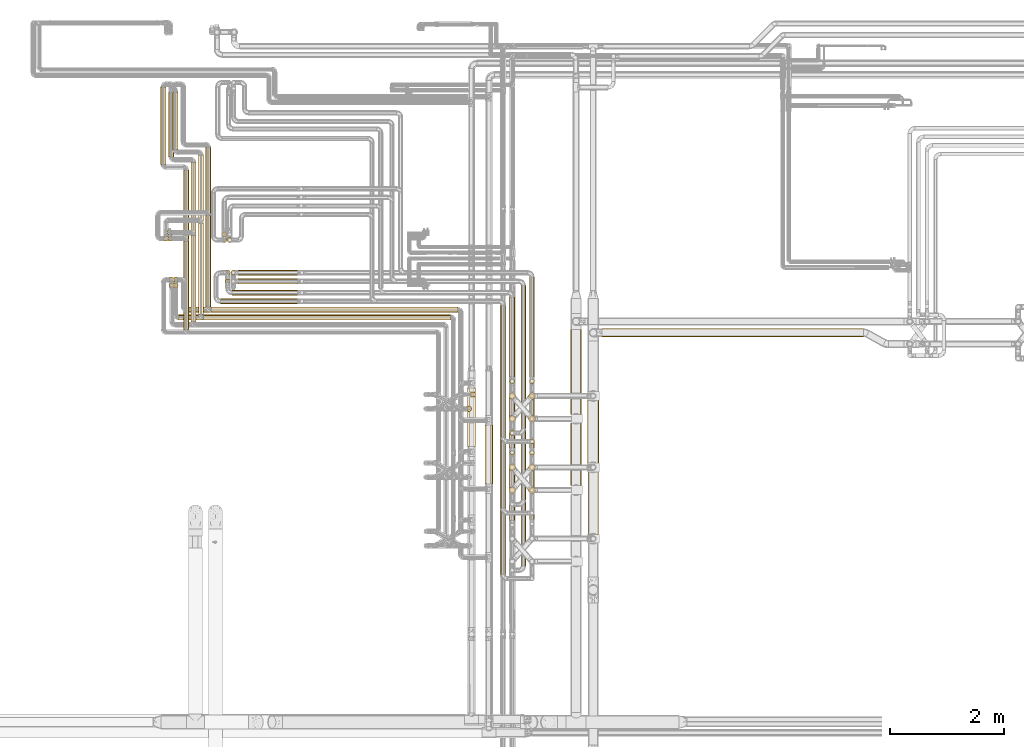
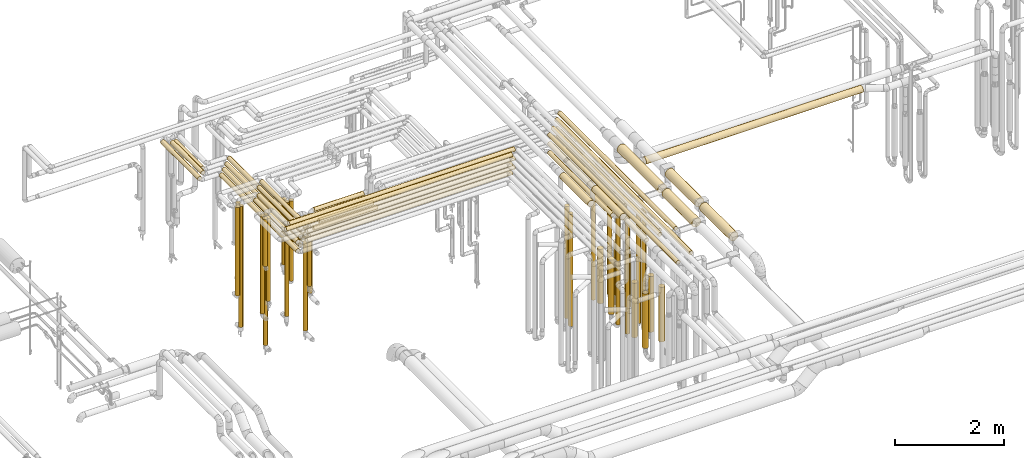
# One storey, part 5 of 827: 69 coverings.
"""IFC2X3 building model written with IfcOpenShell, lengths in millimetres."""

from ifc_helpers import new_model, entity, si_unit, converted_unit, derived_unit, direction, frame, origin, origin_2d_with_axis, place, context, subcontext, project, spatial, polyline, circle, outline, extrude, element, save


model = new_model("IFC2X3")

# Units and contexts
model_context = context("Model", 3, precision=0.01, world=origin(), true_north=direction((6.12303176911189e-17, 1.0)))
body_context = subcontext(model_context, "Body", "Model", "MODEL_VIEW")
ifc_project = project(units=[si_unit("LENGTHUNIT", "METRE", prefix="MILLI"), si_unit("AREAUNIT", "SQUARE_METRE"), si_unit("VOLUMEUNIT", "CUBIC_METRE"), converted_unit("PLANEANGLEUNIT", "DEGREE", entity("IfcRatioMeasure", 0.0174532925199433), si_unit("PLANEANGLEUNIT", "RADIAN"), dimensions=[0, 0, 0, 0, 0, 0, 0]), si_unit("MASSUNIT", "GRAM", prefix="KILO"), derived_unit("MASSDENSITYUNIT", [(si_unit("MASSUNIT", "GRAM", prefix="KILO"), 1), (si_unit("LENGTHUNIT", "METRE"), -3)]), derived_unit("MOMENTOFINERTIAUNIT", [(si_unit("LENGTHUNIT", "METRE"), 4)]), si_unit("TIMEUNIT", "SECOND"), si_unit("FREQUENCYUNIT", "HERTZ"), si_unit("THERMODYNAMICTEMPERATUREUNIT", "DEGREE_CELSIUS"), derived_unit("THERMALTRANSMITTANCEUNIT", [(si_unit("MASSUNIT", "GRAM", prefix="KILO"), 1), (si_unit("THERMODYNAMICTEMPERATUREUNIT", "KELVIN"), -1), (si_unit("TIMEUNIT", "SECOND"), -3)]), derived_unit("VOLUMETRICFLOWRATEUNIT", [(si_unit("LENGTHUNIT", "METRE"), 3), (si_unit("TIMEUNIT", "SECOND"), -1)]), derived_unit("MASSFLOWRATEUNIT", [(si_unit("MASSUNIT", "GRAM", prefix="KILO"), 1), (si_unit("TIMEUNIT", "SECOND"), -1)]), derived_unit("ROTATIONALFREQUENCYUNIT", [(si_unit("TIMEUNIT", "SECOND"), -1)]), si_unit("ELECTRICCURRENTUNIT", "AMPERE"), si_unit("ELECTRICVOLTAGEUNIT", "VOLT"), si_unit("POWERUNIT", "WATT"), si_unit("FORCEUNIT", "NEWTON", prefix="KILO"), si_unit("ILLUMINANCEUNIT", "LUX"), si_unit("LUMINOUSFLUXUNIT", "LUMEN"), si_unit("LUMINOUSINTENSITYUNIT", "CANDELA"), derived_unit("USERDEFINED", [(si_unit("MASSUNIT", "GRAM", prefix="KILO"), -1), (si_unit("LENGTHUNIT", "METRE"), -2), (si_unit("TIMEUNIT", "SECOND"), 3), (si_unit("LUMINOUSFLUXUNIT", "LUMEN"), 1)]), derived_unit("LINEARVELOCITYUNIT", [(si_unit("LENGTHUNIT", "METRE"), 1), (si_unit("TIMEUNIT", "SECOND"), -1)]), si_unit("PRESSUREUNIT", "PASCAL"), derived_unit("USERDEFINED", [(si_unit("LENGTHUNIT", "METRE"), -2), (si_unit("MASSUNIT", "GRAM", prefix="KILO"), 1), (si_unit("TIMEUNIT", "SECOND"), -2)]), derived_unit("LINEARFORCEUNIT", [(si_unit("MASSUNIT", "GRAM", prefix="KILO"), 1), (si_unit("LENGTHUNIT", "METRE"), 1), (si_unit("TIMEUNIT", "SECOND"), -2), (si_unit("LENGTHUNIT", "METRE"), -1)]), derived_unit("PLANARFORCEUNIT", [(si_unit("MASSUNIT", "GRAM", prefix="KILO"), 1), (si_unit("LENGTHUNIT", "METRE"), 1), (si_unit("TIMEUNIT", "SECOND"), -2), (si_unit("LENGTHUNIT", "METRE"), -2)])], contexts=[model_context])

# Site, building, storey
site_placement = place(None, origin())
site = spatial("IfcSite", under=ifc_project, at=site_placement, CompositionType="ELEMENT")
building_placement = place(site_placement, origin())
building = spatial("IfcBuilding", under=site, at=building_placement, CompositionType="ELEMENT")
storey_placement = place(building_placement, frame((0.0, 0.0, 28200.0)))
storey = spatial("IfcBuildingStorey", under=building, at=storey_placement, Name="08", CompositionType="ELEMENT", Elevation=28200.0)

# Coverings
covering_1_placement = place(storey_placement, frame((31258.78, 14538.0, 3152.25)))
element("IfcCovering", 1, at=covering_1_placement, inside=storey, Name=":ADSK_", ObjectType=":ADSK_", PredefinedType="INSULATION", context=body_context, shape_type="SweptSolid", body=[
    extrude(circle(Radius=46.15, at=origin_2d_with_axis()), frame((47.75, 0.0, 47.75), z_axis=(0.0, 1.0, 0.0), x_axis=(-1.0, 0.0, 0.0)), (0.0, 0.0, 1.0), 1605.20292594585),
])
covering_2_placement = place(storey_placement, frame((31128.78, 14408.0, 3152.25)))
element("IfcCovering", 2, at=covering_2_placement, inside=storey, Name=":ADSK_", ObjectType=":ADSK_", PredefinedType="INSULATION", context=body_context, shape_type="SweptSolid", body=[
    extrude(circle(Radius=46.15, at=origin_2d_with_axis()), frame((47.75, 0.0, 47.75), z_axis=(0.0, 1.0, 0.0), x_axis=(-1.0, 0.0, 0.0)), (0.0, 0.0, 1.0), 1605.20292594584),
])
covering_3_placement = place(storey_placement, frame((31354.52, 14442.26, 3152.25)))
element("IfcCovering", 3, at=covering_3_placement, inside=storey, Name=":ADSK_", ObjectType=":ADSK_", PredefinedType="INSULATION", context=body_context, shape_type="SweptSolid", body=[
    extrude(circle(Radius=46.15, at=origin_2d_with_axis()), frame((0.0, 47.75, 47.75), z_axis=(1.0, 0.0, 0.0), x_axis=(0.0, -1.0, 0.0)), (0.0, 0.0, 1.0), 4327.51165000005),
])
covering_4_placement = place(storey_placement, frame((31224.52, 14312.26, 3152.25)))
element("IfcCovering", 4, at=covering_4_placement, inside=storey, Name=":ADSK_", ObjectType=":ADSK_", PredefinedType="INSULATION", context=body_context, shape_type="SweptSolid", body=[
    extrude(circle(Radius=46.15, at=origin_2d_with_axis()), frame((0.0, 47.75, 47.75), z_axis=(1.0, 0.0, 0.0), x_axis=(0.0, -1.0, 0.0)), (0.0, 0.0, 1.0), 4327.56910000005),
])
covering_5_placement = place(storey_placement, frame((35847.22, 12092.08, 3479.16)))
element("IfcCovering", 5, at=covering_5_placement, inside=storey, Name=":ADSK_", ObjectType=":ADSK_", PredefinedType="INSULATION", context=body_context, shape_type="SweptSolid", body=[
    extrude(circle(Radius=69.25, at=origin_2d_with_axis()), frame((70.85, 0.0, 70.85), z_axis=(0.0, 1.0, -9.11558855625522e-08), x_axis=(1.0, 0.0, 0.0)), (0.0, 0.0, 1.0), 1028.00000000001),
])
covering_6_placement = place(storey_placement, frame((30779.54, 14312.26, 3352.25)))
element("IfcCovering", 6, at=covering_6_placement, inside=storey, Name=":ADSK_", ObjectType=":ADSK_", PredefinedType="INSULATION", context=body_context, shape_type="SweptSolid", body=[
    extrude(circle(Radius=46.15, at=origin_2d_with_axis()), frame((0.0, 47.75, 47.75), z_axis=(1.0, 0.0, 0.0), x_axis=(0.0, -1.0, 0.0)), (0.0, 0.0, 1.0), 4772.54583000002),
])
covering_7_placement = place(storey_placement, frame((30921.54, 14442.26, 3352.25)))
element("IfcCovering", 7, at=covering_7_placement, inside=storey, Name=":ADSK_", ObjectType=":ADSK_", PredefinedType="INSULATION", context=body_context, shape_type="SweptSolid", body=[
    extrude(circle(Radius=46.15, at=origin_2d_with_axis()), frame((0.0, 47.75, 47.75), z_axis=(1.0, 0.0, 0.0), x_axis=(0.0, -1.0, 0.0)), (0.0, 0.0, 1.0), 4760.48838000002),
])
covering_8_placement = place(storey_placement, frame((30683.55, 14968.46, 455.5)))
element("IfcCovering", 8, at=covering_8_placement, inside=storey, Name=":ADSK_", ObjectType=":ADSK_", PredefinedType="INSULATION", context=body_context, shape_type="SweptSolid", body=[
    extrude(circle(Radius=46.15, at=origin_2d_with_axis()), frame((47.75, 47.75, 0.0), z_axis=(0.0, 0.0, 1.0), x_axis=(0.0, 1.0, 0.0)), (0.0, 0.0, 1.0), 2896.50000000002),
])
covering_9_placement = place(storey_placement, frame((30683.8, 14868.46, 1500.5)))
element("IfcCovering", 9, at=covering_9_placement, inside=storey, Name=":ADSK_", ObjectType=":ADSK_", PredefinedType="INSULATION", context=body_context, shape_type="SweptSolid", body=[
    extrude(circle(Radius=46.15, at=origin_2d_with_axis()), frame((47.75, 47.75, 0.0), z_axis=(0.0, 0.0, 1.0), x_axis=(-1.0, 0.0, 0.0)), (0.0, 0.0, 1.0), 1851.50000000002),
])
covering_10_placement = place(storey_placement, frame((30515.78, 15693.46, 1178.45)))
element("IfcCovering", 10, at=covering_10_placement, inside=storey, Name=":ADSK_", ObjectType=":ADSK_", PredefinedType="INSULATION", context=body_context, shape_type="SweptSolid", body=[
    extrude(circle(Radius=46.15, at=origin_2d_with_axis()), frame((47.75, 47.75, 0.0), z_axis=(0.0, 0.0, 1.0), x_axis=(0.0, 1.0, 0.0)), (0.0, 0.0, 1.0), 1973.5517399999),
])
covering_11_placement = place(storey_placement, frame((30998.78, 14278.0, 3152.25)))
element("IfcCovering", 11, at=covering_11_placement, inside=storey, Name=":ADSK_", ObjectType=":ADSK_", PredefinedType="INSULATION", context=body_context, shape_type="SweptSolid", body=[
    extrude(circle(Radius=46.15, at=origin_2d_with_axis()), frame((47.75, 0.0, 47.75), z_axis=(0.0, 1.0, 0.0), x_axis=(-1.0, 0.0, 0.0)), (0.0, 0.0, 1.0), 1515.20292594584),
])
covering_12_placement = place(storey_placement, frame((30868.78, 14148.0, 3152.25)))
element("IfcCovering", 12, at=covering_12_placement, inside=storey, Name=":ADSK_", ObjectType=":ADSK_", PredefinedType="INSULATION", context=body_context, shape_type="SweptSolid", body=[
    extrude(circle(Radius=46.15, at=origin_2d_with_axis()), frame((47.75, 0.0, 47.75), z_axis=(0.0, 1.0, 0.0), x_axis=(-1.0, 0.0, 0.0)), (0.0, 0.0, 1.0), 1545.20292594584),
])
covering_13_placement = place(storey_placement, frame((36149.19, 11442.08, 3479.15)))
element("IfcCovering", 13, at=covering_13_placement, inside=storey, Name=":ADSK_", ObjectType=":ADSK_", PredefinedType="INSULATION", context=body_context, shape_type="SweptSolid", body=[
    extrude(circle(Radius=69.25, at=origin_2d_with_axis()), frame((70.85, 0.0, 70.85), z_axis=(0.0, 1.0, -9.11558897760429e-08), x_axis=(1.0, 0.0, 0.0)), (0.0, 0.0, 1.0), 1028.00000000001),
])
covering_14_placement = place(storey_placement, frame((30622.59, 14868.46, 2298.45)))
element("IfcCovering", 14, at=covering_14_placement, inside=storey, Name=":ADSK_", ObjectType=":ADSK_", PredefinedType="INSULATION", context=body_context, shape_type="SweptSolid", body=[
    extrude(circle(Radius=46.15, at=origin_2d_with_axis()), frame((47.75, 47.75, 0.0), z_axis=(0.0, 0.0, 1.0), x_axis=(-1.0, 0.0, 0.0)), (0.0, 0.0, 1.0), 1053.55173999999),
])
covering_15_placement = place(storey_placement, frame((30618.78, 14968.46, 1178.45)))
element("IfcCovering", 15, at=covering_15_placement, inside=storey, Name=":ADSK_", ObjectType=":ADSK_", PredefinedType="INSULATION", context=body_context, shape_type="SweptSolid", body=[
    extrude(circle(Radius=46.15, at=origin_2d_with_axis()), frame((47.75, 47.75, 0.0), z_axis=(0.0, 0.0, 1.0), x_axis=(0.0, 1.0, 0.0)), (0.0, 0.0, 1.0), 2173.55173999987),
])
covering_16_placement = place(storey_placement, frame((30583.78, 15793.46, 1500.5)))
element("IfcCovering", 16, at=covering_16_placement, inside=storey, Name=":ADSK_", ObjectType=":ADSK_", PredefinedType="INSULATION", context=body_context, shape_type="SweptSolid", body=[
    extrude(circle(Radius=46.15, at=origin_2d_with_axis()), frame((47.75, 47.75, 0.0), z_axis=(0.0, 0.0, 1.0), x_axis=(0.0, -1.0, 0.0)), (0.0, 0.0, 1.0), 1651.50000000004),
])
covering_17_placement = place(storey_placement, frame((30583.78, 15693.46, 455.5)))
element("IfcCovering", 17, at=covering_17_placement, inside=storey, Name=":ADSK_", ObjectType=":ADSK_", PredefinedType="INSULATION", context=body_context, shape_type="SweptSolid", body=[
    extrude(circle(Radius=46.15, at=origin_2d_with_axis()), frame((47.75, 47.75, 0.0), z_axis=(0.0, 0.0, 1.0), x_axis=(-1.0, 0.0, 0.0)), (0.0, 0.0, 1.0), 2696.50000000011),
])
covering_18_placement = place(storey_placement, frame((30677.33, 17299.2, 2952.25)))
element("IfcCovering", 18, at=covering_18_placement, inside=storey, Name=":ADSK_", ObjectType=":ADSK_", PredefinedType="INSULATION", context=body_context, shape_type="SweptSolid", body=[
    extrude(circle(Radius=46.15, at=origin_2d_with_axis()), frame((47.75, 0.0, 47.75), z_axis=(0.0, 1.0, 0.0), x_axis=(1.0, 0.0, 0.0)), (0.0, 0.0, 1.0), 993.999999999995),
])
covering_19_placement = place(storey_placement, frame((31128.78, 14408.0, 2952.25)))
element("IfcCovering", 19, at=covering_19_placement, inside=storey, Name=":ADSK_", ObjectType=":ADSK_", PredefinedType="INSULATION", context=body_context, shape_type="SweptSolid", body=[
    extrude(circle(Radius=46.15, at=origin_2d_with_axis()), frame((47.75, 0.0, 47.75), z_axis=(0.0, 1.0, 0.0), x_axis=(1.0, 0.0, 0.0)), (0.0, 0.0, 1.0), 2795.20292594584),
])
covering_20_placement = place(storey_placement, frame((31224.52, 14312.26, 2952.25)))
element("IfcCovering", 20, at=covering_20_placement, inside=storey, Name=":ADSK_", ObjectType=":ADSK_", PredefinedType="INSULATION", context=body_context, shape_type="SweptSolid", body=[
    extrude(circle(Radius=46.15, at=origin_2d_with_axis()), frame((0.0, 47.75, 47.75), z_axis=(1.0, 0.0, 0.0), x_axis=(0.0, 1.0, 0.0)), (0.0, 0.0, 1.0), 4327.56910000003),
])
covering_21_placement = place(storey_placement, frame((30609.3, 17169.2, 2952.25)))
element("IfcCovering", 21, at=covering_21_placement, inside=storey, Name=":ADSK_", ObjectType=":ADSK_", PredefinedType="INSULATION", context=body_context, shape_type="SweptSolid", body=[
    extrude(circle(Radius=46.15, at=origin_2d_with_axis()), frame((47.75, 0.0, 47.75), z_axis=(0.0, 1.0, 0.0), x_axis=(-1.0, 0.0, 0.0)), (0.0, 0.0, 1.0), 1124.0),
])
covering_22_placement = place(storey_placement, frame((30998.78, 14278.0, 2952.25)))
element("IfcCovering", 22, at=covering_22_placement, inside=storey, Name=":ADSK_", ObjectType=":ADSK_", PredefinedType="INSULATION", context=body_context, shape_type="SweptSolid", body=[
    extrude(circle(Radius=46.15, at=origin_2d_with_axis()), frame((47.75, 0.0, 47.75), z_axis=(0.0, 1.0, 0.0), x_axis=(1.0, 0.0, 0.0)), (0.0, 0.0, 1.0), 2795.20292594584),
])
covering_23_placement = place(storey_placement, frame((35826.04, 12708.42, 448.0)))
element("IfcCovering", 23, at=covering_23_placement, inside=storey, Name=":ADSK_", ObjectType=":ADSK_", PredefinedType="INSULATION", context=body_context, shape_type="SweptSolid", body=[
    extrude(circle(Radius=46.15, at=origin_2d_with_axis()), frame((47.75, 47.75, 0.0), z_axis=(0.0, 0.0, 1.0), x_axis=(-1.0, 0.0, 0.0)), (0.0, 0.0, 1.0), 2504.0),
])
covering_24_placement = place(storey_placement, frame((31354.52, 14442.26, 2952.25)))
element("IfcCovering", 24, at=covering_24_placement, inside=storey, Name=":ADSK_", ObjectType=":ADSK_", PredefinedType="INSULATION", context=body_context, shape_type="SweptSolid", body=[
    extrude(circle(Radius=46.15, at=origin_2d_with_axis()), frame((0.0, 47.75, 47.75), z_axis=(1.0, 0.0, 0.0), x_axis=(0.0, 1.0, 0.0)), (0.0, 0.0, 1.0), 4327.51165000003),
])
covering_25_placement = place(storey_placement, frame((31258.78, 14538.0, 2952.25)))
element("IfcCovering", 25, at=covering_25_placement, inside=storey, Name=":ADSK_", ObjectType=":ADSK_", PredefinedType="INSULATION", context=body_context, shape_type="SweptSolid", body=[
    extrude(circle(Radius=46.15, at=origin_2d_with_axis()), frame((47.75, 0.0, 47.75), z_axis=(0.0, 1.0, 0.0), x_axis=(-1.0, 0.0, 0.0)), (0.0, 0.0, 1.0), 2795.20292594584),
])
covering_26_placement = place(storey_placement, frame((35895.3, 12958.46, 448.0)))
element("IfcCovering", 26, at=covering_26_placement, inside=storey, Name=":ADSK_", ObjectType=":ADSK_", PredefinedType="INSULATION", context=body_context, shape_type="SweptSolid", body=[
    extrude(circle(Radius=46.15, at=origin_2d_with_axis()), frame((47.75, 47.75, 0.0), z_axis=(0.0, 0.0, 1.0), x_axis=(-1.0, 0.0, 0.0)), (0.0, 0.0, 1.0), 2504.0),
])
covering_27_placement = place(storey_placement, frame((30467.3, 17039.2, 2952.25)))
element("IfcCovering", 27, at=covering_27_placement, inside=storey, Name=":ADSK_", ObjectType=":ADSK_", PredefinedType="INSULATION", context=body_context, shape_type="SweptSolid", body=[
    extrude(circle(Radius=46.15, at=origin_2d_with_axis()), frame((47.75, 0.0, 47.75), z_axis=(0.0, 1.0, 0.0), x_axis=(-1.0, 0.0, 0.0)), (0.0, 0.0, 1.0), 1353.99999995382),
])
covering_28_placement = place(storey_placement, frame((30868.78, 14148.0, 2952.25)))
element("IfcCovering", 28, at=covering_28_placement, inside=storey, Name=":ADSK_", ObjectType=":ADSK_", PredefinedType="INSULATION", context=body_context, shape_type="SweptSolid", body=[
    extrude(circle(Radius=46.15, at=origin_2d_with_axis()), frame((47.75, 0.0, 47.75), z_axis=(0.0, 1.0, 0.0), x_axis=(1.0, 0.0, 0.0)), (0.0, 0.0, 1.0), 2795.20292594584),
])
covering_29_placement = place(storey_placement, frame((36423.44, 12257.17, 2953.4)))
element("IfcCovering", 29, at=covering_29_placement, inside=storey, Name=":ADSK_", ObjectType=":ADSK_", PredefinedType="INSULATION", context=body_context, shape_type="SweptSolid", body=[
    extrude(circle(Radius=45.0, at=origin_2d_with_axis()), frame((46.6, 0.0, 46.6), z_axis=(0.0, 1.0, 0.0), x_axis=(-1.0, 0.0, 0.0)), (0.0, 0.0, 1.0), 2306.8258040542),
])
covering_30_placement = place(storey_placement, frame((36928.44, 12134.58, 476.0)))
element("IfcCovering", 30, at=covering_30_placement, inside=storey, Name=":ADSK_", ObjectType=":ADSK_", PredefinedType="INSULATION", context=body_context, shape_type="SweptSolid", body=[
    extrude(outline(polyline([(-5.87, -44.62), (5.87, -44.62), (17.22, -41.57), (27.39, -35.7), (35.7, -27.39), (41.57, -17.22), (44.62, -5.87), (44.62, 5.87), (41.57, 17.22), (35.7, 27.39), (27.39, 35.7), (17.22, 41.57), (5.87, 44.62), (-5.87, 44.62), (-17.22, 41.57), (-27.39, 35.7), (-35.7, 27.39), (-41.57, 17.22), (-44.62, 5.87), (-44.62, -5.87), (-41.57, -17.22), (-35.7, -27.39), (-27.39, -35.7), (-17.22, -41.57), (-5.87, -44.62)])), frame((46.6, 46.6, 0.0), z_axis=(-3.67749217620578e-09, 0.0, 1.0), x_axis=(-0.130526192220067, 0.991444861373808, 0.0)), (0.0, 0.0, 1.0), 2447.99999099997),
])
covering_31_placement = place(storey_placement, frame((36583.05, 13316.2, 2953.4)))
element("IfcCovering", 31, at=covering_31_placement, inside=storey, Name=":ADSK_", ObjectType=":ADSK_", PredefinedType="INSULATION", context=body_context, shape_type="SweptSolid", body=[
    extrude(circle(Radius=45.0, at=origin_2d_with_axis()), frame((46.6, 0.0, 46.6), z_axis=(0.0, 1.0, 0.0), x_axis=(1.0, 0.0, 0.0)), (0.0, 0.0, 1.0), 1397.79727405418),
])
covering_32_placement = place(storey_placement, frame((36583.05, 13193.61, 476.0)))
element("IfcCovering", 32, at=covering_32_placement, inside=storey, Name=":ADSK_", ObjectType=":ADSK_", PredefinedType="INSULATION", context=body_context, shape_type="SweptSolid", body=[
    extrude(circle(Radius=45.0, at=origin_2d_with_axis()), frame((46.6, 46.6, 0.0)), (0.0, 0.0, 1.0), 2447.99999999999),
])
covering_33_placement = place(storey_placement, frame((36423.44, 11007.17, 3153.4)))
element("IfcCovering", 33, at=covering_33_placement, inside=storey, Name=":ADSK_", ObjectType=":ADSK_", PredefinedType="INSULATION", context=body_context, shape_type="SweptSolid", body=[
    extrude(circle(Radius=45.0, at=origin_2d_with_axis()), frame((46.6, 0.0, 46.6), z_axis=(0.0, 1.0, 0.0), x_axis=(-1.0, 0.0, 0.0)), (0.0, 0.0, 1.0), 3556.82579505427),
])
covering_34_placement = place(storey_placement, frame((36583.05, 12066.2, 3153.4)))
element("IfcCovering", 34, at=covering_34_placement, inside=storey, Name=":ADSK_", ObjectType=":ADSK_", PredefinedType="INSULATION", context=body_context, shape_type="SweptSolid", body=[
    extrude(circle(Radius=45.0, at=origin_2d_with_axis()), frame((46.6, 0.0, 46.6), z_axis=(0.0, 1.0, 0.0), x_axis=(1.0, 0.0, 0.0)), (0.0, 0.0, 1.0), 2647.79726505419),
])
covering_35_placement = place(storey_placement, frame((36423.44, 9857.02, 3353.4)))
element("IfcCovering", 35, at=covering_35_placement, inside=storey, Name=":ADSK_", ObjectType=":ADSK_", PredefinedType="INSULATION", context=body_context, shape_type="SweptSolid", body=[
    extrude(circle(Radius=45.0, at=origin_2d_with_axis()), frame((46.6, 0.0, 46.6), z_axis=(0.0, 1.0, 0.0), x_axis=(-1.0, 0.0, 0.0)), (0.0, 0.0, 1.0), 4706.97582205429),
])
covering_36_placement = place(storey_placement, frame((36583.05, 10795.72, 3353.4)))
element("IfcCovering", 36, at=covering_36_placement, inside=storey, Name=":ADSK_", ObjectType=":ADSK_", PredefinedType="INSULATION", context=body_context, shape_type="SweptSolid", body=[
    extrude(circle(Radius=45.0, at=origin_2d_with_axis()), frame((46.6, 0.0, 46.6), z_axis=(0.0, 1.0, 0.0), x_axis=(-1.0, 0.0, 0.0)), (0.0, 0.0, 1.0), 3918.27777979508),
])
covering_37_placement = place(storey_placement, frame((36583.05, 11943.61, 476.0)))
element("IfcCovering", 37, at=covering_37_placement, inside=storey, Name=":ADSK_", ObjectType=":ADSK_", PredefinedType="INSULATION", context=body_context, shape_type="SweptSolid", body=[
    extrude(circle(Radius=45.0, at=origin_2d_with_axis()), frame((46.6, 46.6, 0.0)), (0.0, 0.0, 1.0), 2648.0),
])
covering_38_placement = place(storey_placement, frame((36568.8, 11669.36, 565.0)))
element("IfcCovering", 38, at=covering_38_placement, inside=storey, Name=":ADSK_", ObjectType=":ADSK_", PredefinedType="INSULATION", context=body_context, shape_type="SweptSolid", body=[
    extrude(circle(Radius=59.25, at=origin_2d_with_axis()), frame((60.85, 60.85, 0.0), z_axis=(0.0, 0.0, 1.0), x_axis=(-1.0, 0.0, 0.0)), (0.0, 0.0, 1.0), 1215.99999999999),
])
covering_39_placement = place(storey_placement, frame((31517.75, 14593.41, 2953.4)))
element("IfcCovering", 39, at=covering_39_placement, inside=storey, Name=":ADSK_", ObjectType=":ADSK_", PredefinedType="INSULATION", context=body_context, shape_type="SweptSolid", body=[
    extrude(circle(Radius=45.0, at=origin_2d_with_axis()), frame((0.0, 46.6, 46.6), z_axis=(1.0, 0.0, 0.0), x_axis=(0.0, -1.0, 0.0)), (0.0, 0.0, 1.0), 1351.28244),
])
covering_40_placement = place(storey_placement, frame((31722.75, 14743.41, 2953.4)))
element("IfcCovering", 40, at=covering_40_placement, inside=storey, Name=":ADSK_", ObjectType=":ADSK_", PredefinedType="INSULATION", context=body_context, shape_type="SweptSolid", body=[
    extrude(circle(Radius=45.0, at=origin_2d_with_axis()), frame((0.0, 46.6, 46.6), z_axis=(1.0, 0.0, 0.0), x_axis=(0.0, 1.0, 0.0)), (0.0, 0.0, 1.0), 1146.28244),
])
covering_41_placement = place(storey_placement, frame((31600.16, 15092.41, 379.5)))
element("IfcCovering", 41, at=covering_41_placement, inside=storey, Name=":ADSK_", ObjectType=":ADSK_", PredefinedType="INSULATION", context=body_context, shape_type="SweptSolid", body=[
    extrude(circle(Radius=45.0, at=origin_2d_with_axis()), frame((46.6, 46.6, 0.0), z_axis=(0.0, 0.0, 1.0), x_axis=(0.0, -1.0, 0.0)), (0.0, 0.0, 1.0), 2544.50000000001),
])
covering_42_placement = place(storey_placement, frame((31600.16, 14942.41, 1469.5)))
element("IfcCovering", 42, at=covering_42_placement, inside=storey, Name=":ADSK_", ObjectType=":ADSK_", PredefinedType="INSULATION", context=body_context, shape_type="SweptSolid", body=[
    extrude(circle(Radius=45.0, at=origin_2d_with_axis()), frame((46.6, 46.6, 0.0), z_axis=(0.0, 0.0, 1.0), x_axis=(-1.0, 0.0, 0.0)), (0.0, 0.0, 1.0), 1454.50000000002),
])
covering_43_placement = place(storey_placement, frame((31633.66, 15664.61, 1136.0)))
element("IfcCovering", 43, at=covering_43_placement, inside=storey, Name=":ADSK_", ObjectType=":ADSK_", PredefinedType="INSULATION", context=body_context, shape_type="SweptSolid", body=[
    extrude(circle(Radius=45.0, at=origin_2d_with_axis()), frame((46.6, 46.6, 0.0), z_axis=(0.0, 0.0, 1.0), x_axis=(0.0, 1.0, 0.0)), (0.0, 0.0, 1.0), 1788.00000000001),
])
covering_44_placement = place(storey_placement, frame((36914.19, 11269.36, 589.0)))
element("IfcCovering", 44, at=covering_44_placement, inside=storey, Name=":ADSK_", ObjectType=":ADSK_", PredefinedType="INSULATION", context=body_context, shape_type="SweptSolid", body=[
    extrude(circle(Radius=59.25, at=origin_2d_with_axis()), frame((60.85, 60.85, 0.0), z_axis=(0.0, 0.0, 1.0), x_axis=(0.0, -1.0, 0.0)), (0.0, 0.0, 1.0), 1222.00000649532),
])
covering_45_placement = place(storey_placement, frame((36914.19, 12520.33, 589.0)))
element("IfcCovering", 45, at=covering_45_placement, inside=storey, Name=":ADSK_", ObjectType=":ADSK_", PredefinedType="INSULATION", context=body_context, shape_type="SweptSolid", body=[
    extrude(circle(Radius=59.25, at=origin_2d_with_axis()), frame((60.85, 60.85, 0.0), z_axis=(0.0, 0.0, 1.0), x_axis=(0.0, 1.0, 0.0)), (0.0, 0.0, 1.0), 1222.00000649531),
])
covering_46_placement = place(storey_placement, frame((36568.8, 12919.36, 565.0)))
element("IfcCovering", 46, at=covering_46_placement, inside=storey, Name=":ADSK_", ObjectType=":ADSK_", PredefinedType="INSULATION", context=body_context, shape_type="SweptSolid", body=[
    extrude(circle(Radius=59.25, at=origin_2d_with_axis()), frame((60.85, 60.85, 0.0), z_axis=(0.0, 0.0, 1.0), x_axis=(0.0, 1.0, 0.0)), (0.0, 0.0, 1.0), 1216.00000000001),
])
covering_47_placement = place(storey_placement, frame((38200.3, 14015.32, 2426.4)))
element("IfcCovering", 47, at=covering_47_placement, inside=storey, Name=":ADSK_", ObjectType=":ADSK_", PredefinedType="INSULATION", context=body_context, shape_type="SweptSolid", body=[
    extrude(circle(Radius=72.0, at=origin_2d_with_axis()), frame((0.0, 73.6, 73.6), z_axis=(1.0, 0.0, 0.0), x_axis=(0.0, -1.0, 0.0)), (0.0, 0.0, 1.0), 4582.2791782302),
])
covering_48_placement = place(storey_placement, frame((36928.44, 13316.2, 2953.4)))
element("IfcCovering", 48, at=covering_48_placement, inside=storey, Name=":ADSK_", ObjectType=":ADSK_", PredefinedType="INSULATION", context=body_context, shape_type="SweptSolid", body=[
    extrude(circle(Radius=45.0, at=origin_2d_with_axis()), frame((46.6, 0.0, 46.6), z_axis=(0.0, 1.0, 0.0), x_axis=(-1.0, 0.0, 0.0)), (0.0, 0.0, 1.0), 1746.7974740542),
])
covering_49_placement = place(storey_placement, frame((36778.44, 12407.17, 2953.4)))
element("IfcCovering", 49, at=covering_49_placement, inside=storey, Name=":ADSK_", ObjectType=":ADSK_", PredefinedType="INSULATION", context=body_context, shape_type="SweptSolid", body=[
    extrude(circle(Radius=45.0, at=origin_2d_with_axis()), frame((46.6, 0.0, 46.6), z_axis=(0.0, 1.0, 0.0), x_axis=(1.0, 0.0, 0.0)), (0.0, 0.0, 1.0), 2505.82601323927),
])
covering_50_placement = place(storey_placement, frame((36928.44, 13193.61, 476.0)))
element("IfcCovering", 50, at=covering_50_placement, inside=storey, Name=":ADSK_", ObjectType=":ADSK_", PredefinedType="INSULATION", context=body_context, shape_type="SweptSolid", body=[
    extrude(circle(Radius=45.0, at=origin_2d_with_axis()), frame((46.6, 46.6, 0.0)), (0.0, 0.0, 1.0), 2448.0),
])
covering_51_placement = place(storey_placement, frame((36583.05, 12284.58, 476.0)))
element("IfcCovering", 51, at=covering_51_placement, inside=storey, Name=":ADSK_", ObjectType=":ADSK_", PredefinedType="INSULATION", context=body_context, shape_type="SweptSolid", body=[
    extrude(circle(Radius=45.0, at=origin_2d_with_axis()), frame((46.6, 46.6, 0.0), z_axis=(0.0, 0.0, 1.0), x_axis=(0.0, -1.0, 0.0)), (0.0, 0.0, 1.0), 2447.99999099998),
])
covering_52_placement = place(storey_placement, frame((36928.44, 12066.2, 3153.4)))
element("IfcCovering", 52, at=covering_52_placement, inside=storey, Name=":ADSK_", ObjectType=":ADSK_", PredefinedType="INSULATION", context=body_context, shape_type="SweptSolid", body=[
    extrude(circle(Radius=45.0, at=origin_2d_with_axis()), frame((46.6, 0.0, 46.6), z_axis=(0.0, 1.0, 0.0), x_axis=(-1.0, 0.0, 0.0)), (0.0, 0.0, 1.0), 2996.79746505423),
])
covering_53_placement = place(storey_placement, frame((36778.44, 11157.17, 3153.4)))
element("IfcCovering", 53, at=covering_53_placement, inside=storey, Name=":ADSK_", ObjectType=":ADSK_", PredefinedType="INSULATION", context=body_context, shape_type="SweptSolid", body=[
    extrude(circle(Radius=45.0, at=origin_2d_with_axis()), frame((46.6, 0.0, 46.6), z_axis=(0.0, 1.0, 0.0), x_axis=(-1.0, 0.0, 0.0)), (0.0, 0.0, 1.0), 3755.82600423931),
])
covering_54_placement = place(storey_placement, frame((36928.44, 10816.2, 3353.4)))
element("IfcCovering", 54, at=covering_54_placement, inside=storey, Name=":ADSK_", ObjectType=":ADSK_", PredefinedType="INSULATION", context=body_context, shape_type="SweptSolid", body=[
    extrude(circle(Radius=45.0, at=origin_2d_with_axis()), frame((46.6, 0.0, 46.6), z_axis=(0.0, 1.0, 0.0), x_axis=(-1.0, 0.0, 0.0)), (0.0, 0.0, 1.0), 4247.79746505422),
])
covering_55_placement = place(storey_placement, frame((36778.44, 10002.17, 3353.4)))
element("IfcCovering", 55, at=covering_55_placement, inside=storey, Name=":ADSK_", ObjectType=":ADSK_", PredefinedType="INSULATION", context=body_context, shape_type="SweptSolid", body=[
    extrude(circle(Radius=45.0, at=origin_2d_with_axis()), frame((46.6, 0.0, 46.6), z_axis=(0.0, 1.0, 0.0), x_axis=(1.0, 0.0, 0.0)), (0.0, 0.0, 1.0), 4911.82600423926),
])
covering_56_placement = place(storey_placement, frame((36928.44, 11943.61, 476.0)))
element("IfcCovering", 56, at=covering_56_placement, inside=storey, Name=":ADSK_", ObjectType=":ADSK_", PredefinedType="INSULATION", context=body_context, shape_type="SweptSolid", body=[
    extrude(circle(Radius=45.0, at=origin_2d_with_axis()), frame((46.6, 46.6, 0.0)), (0.0, 0.0, 1.0), 2648.0),
])
covering_57_placement = place(storey_placement, frame((36568.8, 11270.75, 565.0)))
element("IfcCovering", 57, at=covering_57_placement, inside=storey, Name=":ADSK_", ObjectType=":ADSK_", PredefinedType="INSULATION", context=body_context, shape_type="SweptSolid", body=[
    extrude(circle(Radius=59.25, at=origin_2d_with_axis()), frame((60.85, 60.85, 0.0), z_axis=(0.0, 0.0, 1.0), x_axis=(0.0, -1.0, 0.0)), (0.0, 0.0, 1.0), 1215.99999099996),
])
covering_58_placement = place(storey_placement, frame((36914.19, 11669.36, 565.0)))
element("IfcCovering", 58, at=covering_58_placement, inside=storey, Name=":ADSK_", ObjectType=":ADSK_", PredefinedType="INSULATION", context=body_context, shape_type="SweptSolid", body=[
    extrude(circle(Radius=59.25, at=origin_2d_with_axis()), frame((60.85, 60.85, 0.0)), (0.0, 0.0, 1.0), 1246.0),
])
covering_59_placement = place(storey_placement, frame((37952.2, 10557.7, 2903.9)))
element("IfcCovering", 59, at=covering_59_placement, inside=storey, Name=":ADSK_", ObjectType=":ADSK_", PredefinedType="INSULATION", context=body_context, shape_type="SweptSolid", body=[
    extrude(circle(Radius=94.5, at=origin_2d_with_axis()), frame((96.1, 0.0, 96.1), z_axis=(0.0, 1.0, 0.0), x_axis=(1.0, 0.0, 0.0)), (0.0, 0.0, 1.0), 1095.00000000002),
])
covering_60_placement = place(storey_placement, frame((37949.2, 11807.7, 2900.9)))
element("IfcCovering", 60, at=covering_60_placement, inside=storey, Name=":ADSK_", ObjectType=":ADSK_", PredefinedType="INSULATION", context=body_context, shape_type="SweptSolid", body=[
    extrude(circle(Radius=97.5, at=origin_2d_with_axis()), frame((99.1, 0.0, 99.1), z_axis=(0.0, 1.0, 0.0), x_axis=(1.0, 0.0, 0.0)), (0.0, 0.0, 1.0), 1094.43742839127),
])
covering_61_placement = place(storey_placement, frame((31821.03, 15093.41, 2953.4)))
element("IfcCovering", 61, at=covering_61_placement, inside=storey, Name=":ADSK_", ObjectType=":ADSK_", PredefinedType="INSULATION", context=body_context, shape_type="SweptSolid", body=[
    extrude(circle(Radius=45.0, at=origin_2d_with_axis()), frame((0.0, 46.6, 46.6), z_axis=(1.0, 0.0, 0.0), x_axis=(0.0, -1.0, 0.0)), (0.0, 0.0, 1.0), 1048.00000000002),
])
covering_62_placement = place(storey_placement, frame((31821.03, 14943.41, 2953.4)))
element("IfcCovering", 62, at=covering_62_placement, inside=storey, Name=":ADSK_", ObjectType=":ADSK_", PredefinedType="INSULATION", context=body_context, shape_type="SweptSolid", body=[
    extrude(circle(Radius=45.0, at=origin_2d_with_axis()), frame((0.0, 46.6, 46.6), z_axis=(1.0, 0.0, 0.0), x_axis=(0.0, -1.0, 0.0)), (0.0, 0.0, 1.0), 1048.00000000003),
])
covering_63_placement = place(storey_placement, frame((31537.66, 15664.61, 379.5)))
element("IfcCovering", 63, at=covering_63_placement, inside=storey, Name=":ADSK_", ObjectType=":ADSK_", PredefinedType="INSULATION", context=body_context, shape_type="SweptSolid", body=[
    extrude(circle(Radius=45.0, at=origin_2d_with_axis()), frame((46.6, 46.6, 0.0), z_axis=(0.0, 0.0, 1.0), x_axis=(0.0, -1.0, 0.0)), (0.0, 0.0, 1.0), 2544.50000000001),
])
covering_64_placement = place(storey_placement, frame((31537.66, 15764.61, 1469.5)))
element("IfcCovering", 64, at=covering_64_placement, inside=storey, Name=":ADSK_", ObjectType=":ADSK_", PredefinedType="INSULATION", context=body_context, shape_type="SweptSolid", body=[
    extrude(circle(Radius=45.0, at=origin_2d_with_axis()), frame((46.6, 46.6, 0.0), z_axis=(0.0, 0.0, 1.0), x_axis=(-1.0, 0.0, 0.0)), (0.0, 0.0, 1.0), 1454.50000000001),
])
covering_65_placement = place(storey_placement, frame((36914.19, 12918.8, 629.0)))
element("IfcCovering", 65, at=covering_65_placement, inside=storey, Name=":ADSK_", ObjectType=":ADSK_", PredefinedType="INSULATION", context=body_context, shape_type="SweptSolid", body=[
    extrude(circle(Radius=59.25, at=origin_2d_with_axis()), frame((60.85, 60.85, 0.0), z_axis=(0.0, 0.0, 1.0), x_axis=(0.0, -1.0, 0.0)), (0.0, 0.0, 1.0), 1182.0),
])
covering_66_placement = place(storey_placement, frame((36568.83, 12520.33, 564.99)))
element("IfcCovering", 66, at=covering_66_placement, inside=storey, Name=":ADSK_", ObjectType=":ADSK_", PredefinedType="INSULATION", context=body_context, shape_type="SweptSolid", body=[
    extrude(circle(Radius=59.25, at=origin_2d_with_axis()), frame((60.85, 60.85, 0.01), z_axis=(0.000201513087669316, 0.0, 0.999999979696238), x_axis=(0.999999979696238, 0.0, -0.000201513087669316)), (0.0, 0.0, 1.0), 1216.00001903948),
])
covering_67_placement = place(storey_placement, frame((31698.44, 15093.41, 1186.0)))
element("IfcCovering", 67, at=covering_67_placement, inside=storey, Name=":ADSK_", ObjectType=":ADSK_", PredefinedType="INSULATION", context=body_context, shape_type="SweptSolid", body=[
    extrude(circle(Radius=45.0, at=origin_2d_with_axis()), frame((46.6, 46.6, 0.0), z_axis=(0.0, 0.0, 1.0), x_axis=(0.0, 1.0, 0.0)), (0.0, 0.0, 1.0), 1738.00000000001),
])
covering_68_placement = place(storey_placement, frame((37652.2, 12658.67, 2803.81)))
element("IfcCovering", 68, at=covering_68_placement, inside=storey, Name=":ADSK_", ObjectType=":ADSK_", PredefinedType="INSULATION", context=body_context, shape_type="SweptSolid", body=[
    extrude(circle(Radius=94.5, at=origin_2d_with_axis()), frame((96.1, 0.0, 96.1), z_axis=(0.0, 1.0, -7.18992411449206e-07), x_axis=(-1.0, 0.0, 0.0)), (0.0, 0.0, 1.0), 1484.94897976168),
])
covering_69_placement = place(storey_placement, frame((37652.2, 11407.7, 2803.81)))
element("IfcCovering", 69, at=covering_69_placement, inside=storey, Name=":ADSK_", ObjectType=":ADSK_", PredefinedType="INSULATION", context=body_context, shape_type="SweptSolid", body=[
    extrude(circle(Radius=94.5, at=origin_2d_with_axis()), frame((96.1, 0.0, 96.1), z_axis=(0.0, 1.0, -7.18992411449206e-07), x_axis=(-1.0, 0.0, 0.0)), (0.0, 0.0, 1.0), 1095.97124281503),
])

save(model, "model.ifc")
